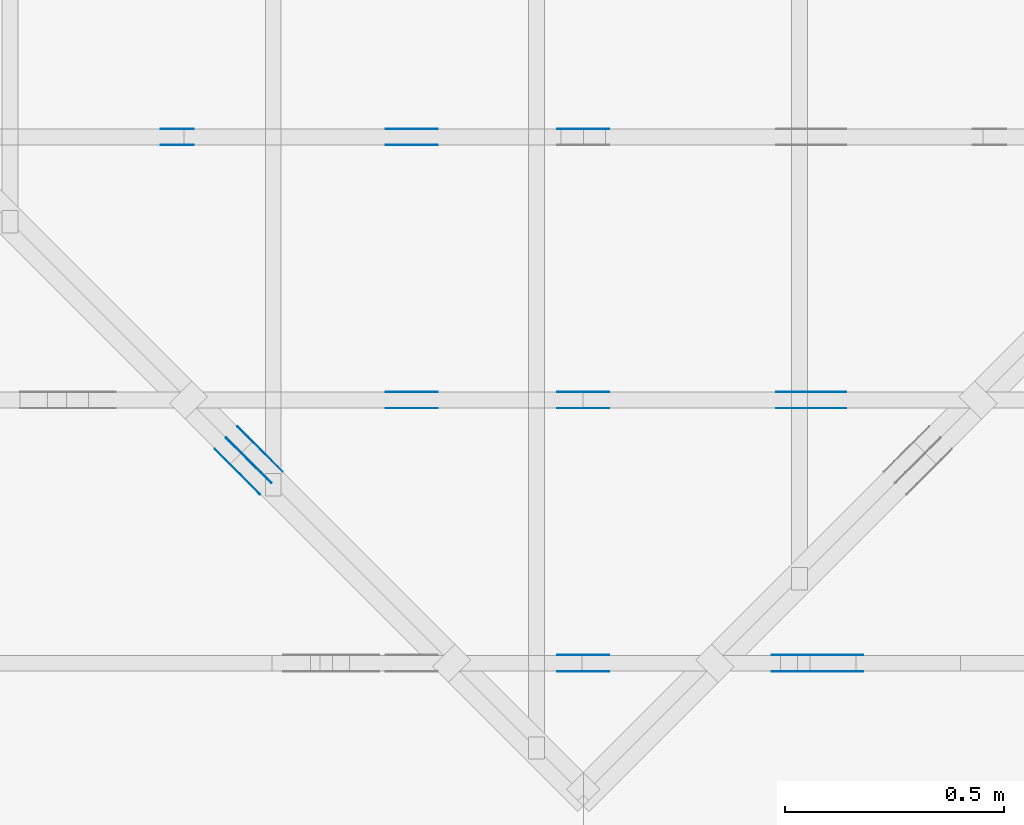
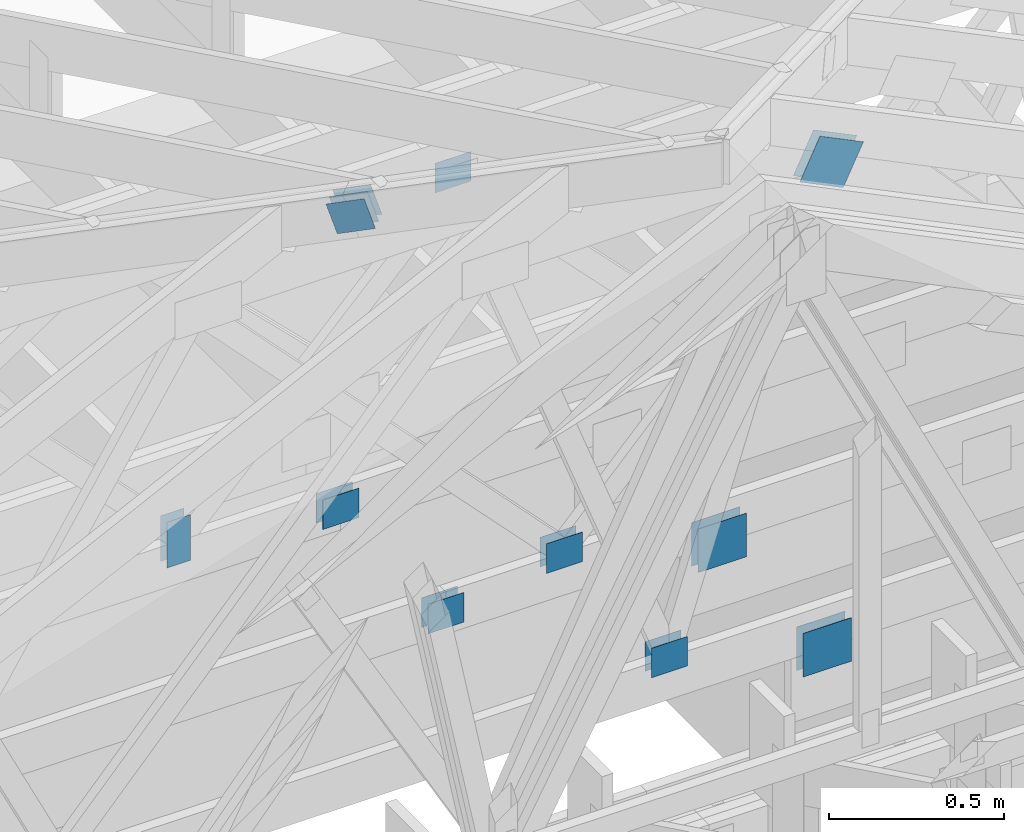
# One storey, part 106 of 159: 21 plates, 4 elements without a shape of their own.
"""IFC2X3 building model written with IfcOpenShell, lengths in millimetres."""

from ifc_helpers import new_model, si_unit, frame, origin, origin_with_axes, origin_2d, place, context, project, spatial, faceted_brep, element, aggregate, save


model = new_model("IFC2X3")

# Units and contexts
model_context = context("Model", 3, precision=1e-05, world=origin())
plan_context = context("Plan", 2, precision=1e-05, world=origin_2d())
ifc_project = project(units=[si_unit("LENGTHUNIT", "METRE", prefix="MILLI"), si_unit("AREAUNIT", "SQUARE_METRE"), si_unit("VOLUMEUNIT", "CUBIC_METRE"), si_unit("SOLIDANGLEUNIT", "STERADIAN"), si_unit("PLANEANGLEUNIT", "RADIAN"), si_unit("MASSUNIT", "GRAM"), si_unit("TIMEUNIT", "SECOND"), si_unit("THERMODYNAMICTEMPERATUREUNIT", "DEGREE_CELSIUS"), si_unit("LUMINOUSINTENSITYUNIT", "LUMEN")], contexts=[model_context, plan_context])

# Site, building, storey
site_placement = place(None, origin_with_axes())
site = spatial("IfcSite", under=ifc_project, at=site_placement, CompositionType="ELEMENT")
building_placement = place(site_placement, origin_with_axes())
building = spatial("IfcBuilding", under=site, at=building_placement, Name="Plan 1", CompositionType="ELEMENT")
storey_placement = place(building_placement, origin_with_axes())
storey = spatial("IfcBuildingStorey", under=building, at=storey_placement, Name="Etasje 1", CompositionType="ELEMENT", Elevation=0.0)

# Assembly, plates
assembly_1_placement = place(storey_placement, frame((19200.01266310149, 9617.999978540158, 1.1021457184401395e-15), z_axis=(1.2246063538223773e-16, 1.0, 6.123031769111886e-17), x_axis=(-1.0, 1.2246063538223773e-16, 0.0)))
assembly_1 = element("IfcElementAssembly", 1, at=assembly_1_placement, inside=storey, Name="V12 (104)", AssemblyPlace="FACTORY", PredefinedType="TRUSS")
plate_1_placement = place(assembly_1_placement, frame((4028.032541300384, 1806.4521257619804, 0.0), z_axis=(0.0, 0.0, 1.0), x_axis=(0.8987940462991673, 0.4383711467890768, 0.0)))
plate_1 = element("IfcPlate", 2, at=plate_1_placement, Name="GNT100S 152x159", context=model_context, shape_type="Brep", body=[
    faceted_brep([(158.99978113527595, 152.0001253083451, 1.0), (8.280817382910755e-05, 152.0001253083451, 1.0), (0.0, 0.0001610444935522537, 1.0), (159.00013719138315, 0.0001610444935522537, 1.0), (8.280817382910755e-05, 152.0001253083451, 1.01407415819553e-20), (158.99978113527595, 152.0001253083451, 1.947121422346263e-14), (159.00013719138315, 0.0, 1.9471257826319747e-14), (0.0, 0.0, 0.0), (159.00000636864752, 0.00011443024701051385, 5.160118521239647e-30), (159.00000636864752, 0.00011443024701057508, 1.0), (6.368647518684156e-06, 0.00011443024732222268, 1.0), (6.368647518684156e-06, 0.00011443024732216145, 0.0), (159.00000636864752, 152.00011443024732, 5.522026336547083e-29), (159.00000636864752, 152.00011443024732, 1.0), (159.00000636864752, 0.00011443024709478777, 1.0), (159.00000636864752, 0.00011443024709478777, 0.0), (6.368647518684156e-06, 152.00011443024687, 0.0), (6.368647518684156e-06, 152.00011443024687, 1.0), (159.0000063686466, 152.00011443024735, 1.0), (159.0000063686466, 152.00011443024735, 3.1554436208840472e-30), (6.368647518684171e-06, 0.00011443024732216145, -8.46355932592047e-37), (6.368647518745401e-06, 0.00011443024732216145, 1.0), (6.3686475373594175e-06, 152.00011443024687, 1.0), (6.368647537298187e-06, 152.00011443024687, -1.1397430066957006e-30)], [[[0, 1, 2, 3]], [[4, 5, 6, 7]], [[8, 9, 10, 11]], [[12, 13, 14, 15]], [[16, 17, 18, 19]], [[20, 21, 22, 23]]]),
])
plate_2_placement = place(assembly_1_placement, frame((4028.032541300384, 1806.4521257619804, -37.0), z_axis=(0.0, 0.0, 1.0), x_axis=(0.8987940462991673, 0.4383711467890768, 0.0)))
plate_2 = element("IfcPlate", 3, at=plate_2_placement, Name="GNT100S 152x159", context=model_context, shape_type="Brep", body=[
    faceted_brep([(158.99978113527595, 152.0001253083451, 1.0), (8.280817382910755e-05, 152.0001253083451, 1.0), (0.0, 0.0001610444935522537, 1.0), (159.00013719138315, 0.0001610444935522537, 1.0), (8.280817382910755e-05, 152.0001253083451, 1.01407415819553e-20), (158.99978113527595, 152.0001253083451, 1.947121422346263e-14), (159.00013719138315, 0.0, 1.9471257826319747e-14), (0.0, 0.0, 0.0), (159.00000636864752, 0.00011443024701051385, 5.160118521239647e-30), (159.00000636864752, 0.00011443024701057508, 1.0), (6.368647518684156e-06, 0.00011443024732222268, 1.0), (6.368647518684156e-06, 0.00011443024732216145, 0.0), (159.00000636864752, 152.00011443024732, 5.522026336547083e-29), (159.00000636864752, 152.00011443024732, 1.0), (159.00000636864752, 0.00011443024709478777, 1.0), (159.00000636864752, 0.00011443024709478777, 0.0), (6.368647518684156e-06, 152.00011443024687, 0.0), (6.368647518684156e-06, 152.00011443024687, 1.0), (159.0000063686466, 152.00011443024735, 1.0), (159.0000063686466, 152.00011443024735, 3.1554436208840472e-30), (6.368647518684171e-06, 0.00011443024732216145, -8.46355932592047e-37), (6.368647518745401e-06, 0.00011443024732216145, 1.0), (6.3686475373594175e-06, 152.00011443024687, 1.0), (6.368647537298187e-06, 152.00011443024687, -1.1397430066957006e-30)], [[[0, 1, 2, 3]], [[4, 5, 6, 7]], [[8, 9, 10, 11]], [[12, 13, 14, 15]], [[16, 17, 18, 19]], [[20, 21, 22, 23]]]),
])
plate_3_placement = place(assembly_1_placement, frame((4540.8310546875, 319.5, 0.0), z_axis=(0.0, 0.0, 1.0), x_axis=(1.0, 0.0, 0.0)))
plate_3 = element("IfcPlate", 4, at=plate_3_placement, Name="GNT100S 103x119", context=model_context, shape_type="Brep", body=[
    faceted_brep([(119.0, 103.0, 1.0), (0.0, 103.0, 1.0), (0.0, 0.0, 1.0), (119.0, 0.0, 1.0), (0.0, 103.0, 0.0), (119.0, 103.0, 1.457281561048629e-14), (119.0, 0.0, 1.457281561048629e-14), (0.0, 0.0, 0.0), (119.0000868137704, 9.444788812711026e-13, 1.338448170660265e-30), (119.0000868137704, 9.445401115887937e-13, 1.0), (8.681377039465588e-05, 9.663993350045231e-13, 1.0), (8.681377039465588e-05, 9.66338104686832e-13, 9.764340073010094e-37), (119.0000868137704, 103.00000000000097, 0.0), (119.0000868137704, 103.00000000000097, 1.0), (119.0000868137704, 9.663381206337363e-13, 1.0), (119.0000868137704, 9.663381206337363e-13, 0.0), (8.681377039465588e-05, 103.00000000000097, 0.0), (8.681377039465588e-05, 103.00000000000097, 1.0), (119.0000868137704, 103.00000000000095, 1.0), (119.0000868137704, 103.00000000000095, -7.888609052210118e-31), (8.681377039465588e-05, 9.663381206337363e-13, 0.0), (8.68137703947171e-05, 9.663381206337363e-13, 1.0), (8.681377040733055e-05, 103.00000000000097, 1.0), (8.681377040726932e-05, 103.00000000000097, -7.723249910891245e-31)], [[[0, 1, 2, 3]], [[4, 5, 6, 7]], [[8, 9, 10, 11]], [[12, 13, 14, 15]], [[16, 17, 18, 19]], [[20, 21, 22, 23]]]),
])
plate_4_placement = place(assembly_1_placement, frame((4540.8310546875, 319.5, -37.0), z_axis=(0.0, 0.0, 1.0), x_axis=(1.0, 0.0, 0.0)))
plate_4 = element("IfcPlate", 5, at=plate_4_placement, Name="GNT100S 103x119", context=model_context, shape_type="Brep", body=[
    faceted_brep([(119.0, 103.0, 1.0), (0.0, 103.0, 1.0), (0.0, 0.0, 1.0), (119.0, 0.0, 1.0), (0.0, 103.0, 0.0), (119.0, 103.0, 1.457281561048629e-14), (119.0, 0.0, 1.457281561048629e-14), (0.0, 0.0, 0.0), (119.0000868137704, 9.444788812711026e-13, 1.338448170660265e-30), (119.0000868137704, 9.445401115887937e-13, 1.0), (8.681377039465588e-05, 9.663993350045231e-13, 1.0), (8.681377039465588e-05, 9.66338104686832e-13, 9.764340073010094e-37), (119.0000868137704, 103.00000000000097, 0.0), (119.0000868137704, 103.00000000000097, 1.0), (119.0000868137704, 9.663381206337363e-13, 1.0), (119.0000868137704, 9.663381206337363e-13, 0.0), (8.681377039465588e-05, 103.00000000000097, 0.0), (8.681377039465588e-05, 103.00000000000097, 1.0), (119.0000868137704, 103.00000000000095, 1.0), (119.0000868137704, 103.00000000000095, -7.888609052210118e-31), (8.681377039465588e-05, 9.663381206337363e-13, 0.0), (8.68137703947171e-05, 9.663381206337363e-13, 1.0), (8.681377040733055e-05, 103.00000000000097, 1.0), (8.681377040726932e-05, 103.00000000000097, -7.723249910891245e-31)], [[[0, 1, 2, 3]], [[4, 5, 6, 7]], [[8, 9, 10, 11]], [[12, 13, 14, 15]], [[16, 17, 18, 19]], [[20, 21, 22, 23]]]),
])
plate_5_placement = place(assembly_1_placement, frame((4160.0, 299.00000000019014, 0.0), z_axis=(0.0, 0.0, 1.0), x_axis=(-1.0, 1.2246063538223773e-16, 0.0)))
plate_5 = element("IfcPlate", 6, at=plate_5_placement, Name="GNT100S 152x159", context=model_context, shape_type="Brep", body=[
    faceted_brep([(159.0, 152.00000000019014, 1.0), (0.0, 152.00000000019014, 1.0), (0.0, 1.901412360894028e-10, 1.0), (159.0, 1.901412360894028e-10, 1.0), (0.0, 152.00000000019014, 0.0), (159.0, 152.00000000019014, 1.9471241025775798e-14), (159.0, 1.901412360894028e-10, 1.9471241025775798e-14), (0.0, 1.901412360894028e-10, 0.0), (159.0, -2.92068615386637e-14, 1.788345410772899e-30), (159.0, -2.914563122097258e-14, 1.0), (1.1247455413666031e-32, 6.123031769111886e-17, 1.0), (0.0, 0.0, 0.0), (159.0, 152.00000000000003, 0.0), (159.0, 152.00000000000003, 1.0), (159.0, 0.0, 1.0), (159.0, 0.0, 0.0), (0.0, 152.0, 0.0), (0.0, 152.0, 1.0), (159.0, 152.00000000000003, 1.0), (159.0, 152.00000000000003, 0.0), (0.0, 0.0, 0.0), (6.123031769111886e-17, -7.498303609110687e-33, 1.0), (1.8675246895791253e-14, 152.0, 1.0), (1.8614016578100134e-14, 152.0, -1.1397421485848245e-30)], [[[0, 1, 2, 3]], [[4, 5, 6, 7]], [[8, 9, 10, 11]], [[12, 13, 14, 15]], [[16, 17, 18, 19]], [[20, 21, 22, 23]]]),
])
plate_6_placement = place(assembly_1_placement, frame((4160.0, 299.00000000019014, -37.0), z_axis=(0.0, 0.0, 1.0), x_axis=(-1.0, 1.2246063538223773e-16, 0.0)))
plate_6 = element("IfcPlate", 7, at=plate_6_placement, Name="GNT100S 152x159", context=model_context, shape_type="Brep", body=[
    faceted_brep([(159.0, 152.00000000019014, 1.0), (0.0, 152.00000000019014, 1.0), (0.0, 1.901412360894028e-10, 1.0), (159.0, 1.901412360894028e-10, 1.0), (0.0, 152.00000000019014, 0.0), (159.0, 152.00000000019014, 1.9471241025775798e-14), (159.0, 1.901412360894028e-10, 1.9471241025775798e-14), (0.0, 1.901412360894028e-10, 0.0), (159.0, -2.92068615386637e-14, 1.788345410772899e-30), (159.0, -2.914563122097258e-14, 1.0), (1.1247455413666031e-32, 6.123031769111886e-17, 1.0), (0.0, 0.0, 0.0), (159.0, 152.00000000000003, 0.0), (159.0, 152.00000000000003, 1.0), (159.0, 0.0, 1.0), (159.0, 0.0, 0.0), (0.0, 152.0, 0.0), (0.0, 152.0, 1.0), (159.0, 152.00000000000003, 1.0), (159.0, 152.00000000000003, 0.0), (0.0, 0.0, 0.0), (6.123031769111886e-17, -7.498303609110687e-33, 1.0), (1.8675246895791253e-14, 152.0, 1.0), (1.8614016578100134e-14, 152.0, -1.1397421485848245e-30)], [[[0, 1, 2, 3]], [[4, 5, 6, 7]], [[8, 9, 10, 11]], [[12, 13, 14, 15]], [[16, 17, 18, 19]], [[20, 21, 22, 23]]]),
])
aggregate(assembly_1, [plate_1, plate_2, plate_3, plate_4, plate_5, plate_6])

assembly_2_placement = place(storey_placement, frame((19200.01266310149, 10817.999978540158, 1.1021457184401395e-15), z_axis=(1.2246063538223773e-16, 1.0, 6.123031769111886e-17), x_axis=(-1.0, 1.2246063538223773e-16, 0.0)))
assembly_2 = element("IfcElementAssembly", 8, at=assembly_2_placement, inside=storey, Name="V10 (59)", AssemblyPlace="FACTORY", PredefinedType="TRUSS")
plate_7_placement = place(assembly_2_placement, frame((4659.5, 1362.0267333984375, 0.0), z_axis=(0.0, 0.0, 1.0), x_axis=(-1.0, 1.2246063538223773e-16, 0.0)))
plate_7 = element("IfcPlate", 9, at=plate_7_placement, Name="GNT100S 103x119", context=model_context, shape_type="Brep", body=[
    faceted_brep([(119.0, 103.0, 1.0), (0.0, 103.0, 1.0), (0.0, 0.0, 1.0), (119.0, 0.0, 1.0), (0.0, 103.0, 0.0), (119.0, 103.0, 1.457281561048629e-14), (119.0, 2.2737367544323206e-13, 1.457281561048629e-14), (0.0, 2.2737367544323206e-13, 0.0), (119.00000000106957, 1.2177599463382107e-05, 2.3173492506686754e-30), (119.00000000106957, 1.2177599463443337e-05, 1.0), (1.0695657692849636e-09, 1.2177599273916097e-05, 1.0), (1.0695657692849636e-09, 1.2177599273854867e-05, 0.0), (119.00000000106957, 103.0000121775995, 0.0), (119.00000000106957, 103.0000121775995, 1.0), (119.00000000106957, 1.2177599501228542e-05, 1.0), (119.00000000106957, 1.2177599501228542e-05, 0.0), (1.0695657692849636e-09, 103.00001217759927, 0.0), (1.0695657692849636e-09, 103.00001217759927, 1.0), (119.00000000106957, 103.0000121775995, 1.0), (119.00000000106957, 103.0000121775995, 0.0), (1.0695657692864548e-09, 1.2177599273854867e-05, -9.130744205508276e-38), (1.0695658305167725e-09, 1.2177599273854867e-05, 1.0), (1.0695784439622169e-09, 103.00001217759927, 1.0), (1.0695783827318992e-09, 103.00001217759927, -7.723253630458428e-31)], [[[0, 1, 2, 3]], [[4, 5, 6, 7]], [[8, 9, 10, 11]], [[12, 13, 14, 15]], [[16, 17, 18, 19]], [[20, 21, 22, 23]]]),
])
plate_8_placement = place(assembly_2_placement, frame((5563.72265625, 291.5, 0.0), z_axis=(0.0, 0.0, 1.0), x_axis=(6.123031769111886e-17, 1.0, 0.0)))
plate_8 = element("IfcPlate", 10, at=plate_8_placement, Name="GNT100S 76x159", context=model_context, shape_type="Brep", body=[
    faceted_brep([(159.0, 76.0, 1.0), (0.0, 76.0, 1.0), (0.0, 0.0, 1.0), (159.0, 0.0, 1.0), (0.0, 76.0, 0.0), (159.0, 76.0, 1.9471241025775798e-14), (159.0, 0.0, 1.9471241025775798e-14), (0.0, 0.0, 0.0), (159.00000000027137, 0.00014167937112496176, 1.7883448193523036e-30), (159.00000000027137, 0.000141679371125023, 1.0), (2.7137048164149746e-10, 0.00014167937115422985, 1.0), (2.7137048164149746e-10, 0.00014167937115416862, 0.0), (159.00000000027137, 76.00014167937115, 0.0), (159.00000000027137, 76.00014167937115, 1.0), (159.00000000027137, 0.00014167937115416862, 1.0), (159.00000000027137, 0.00014167937115416862, 0.0), (2.7137048164149746e-10, 76.00014167937115, 0.0), (2.7137048164149746e-10, 76.00014167937115, 1.0), (159.00000000027137, 76.00014167937114, 1.0), (159.00000000027137, 76.00014167937114, -7.888609052210118e-31), (2.7137048165884763e-10, 0.00014167937115416862, -1.0623558894148973e-36), (2.713705428891653e-10, 0.00014167937115416862, 1.0), (2.7137984989745437e-10, 76.00014167937115, 1.0), (2.713797886671367e-10, 76.00014167937115, -5.698721366483016e-31)], [[[0, 1, 2, 3]], [[4, 5, 6, 7]], [[8, 9, 10, 11]], [[12, 13, 14, 15]], [[16, 17, 18, 19]], [[20, 21, 22, 23]]]),
])
plate_9_placement = place(assembly_2_placement, frame((5563.72265625, 291.5, -37.0), z_axis=(0.0, 0.0, 1.0), x_axis=(6.123031769111886e-17, 1.0, 0.0)))
plate_9 = element("IfcPlate", 11, at=plate_9_placement, Name="GNT100S 76x159", context=model_context, shape_type="Brep", body=[
    faceted_brep([(159.0, 76.0, 1.0), (0.0, 76.0, 1.0), (0.0, 0.0, 1.0), (159.0, 0.0, 1.0), (0.0, 76.0, 0.0), (159.0, 76.0, 1.9471241025775798e-14), (159.0, 0.0, 1.9471241025775798e-14), (0.0, 0.0, 0.0), (159.00000000027137, 0.00014167937112496176, 1.7883448193523036e-30), (159.00000000027137, 0.000141679371125023, 1.0), (2.7137048164149746e-10, 0.00014167937115422985, 1.0), (2.7137048164149746e-10, 0.00014167937115416862, 0.0), (159.00000000027137, 76.00014167937115, 0.0), (159.00000000027137, 76.00014167937115, 1.0), (159.00000000027137, 0.00014167937115416862, 1.0), (159.00000000027137, 0.00014167937115416862, 0.0), (2.7137048164149746e-10, 76.00014167937115, 0.0), (2.7137048164149746e-10, 76.00014167937115, 1.0), (159.00000000027137, 76.00014167937114, 1.0), (159.00000000027137, 76.00014167937114, -7.888609052210118e-31), (2.7137048165884763e-10, 0.00014167937115416862, -1.0623558894148973e-36), (2.713705428891653e-10, 0.00014167937115416862, 1.0), (2.7137984989745437e-10, 76.00014167937115, 1.0), (2.713797886671367e-10, 76.00014167937115, -5.698721366483016e-31)], [[[0, 1, 2, 3]], [[4, 5, 6, 7]], [[8, 9, 10, 11]], [[12, 13, 14, 15]], [[16, 17, 18, 19]], [[20, 21, 22, 23]]]),
])
plate_10_placement = place(assembly_2_placement, frame((5050.6812956836075, 348.50000000000085, 0.0), z_axis=(0.0, 0.0, 1.0), x_axis=(-1.0, 1.2246063538223773e-16, 0.0)))
plate_10 = element("IfcPlate", 12, at=plate_10_placement, Name="GNT100S 103x119", context=model_context, shape_type="Brep", body=[
    faceted_brep([(119.00014333985746, 103.00000000000085, 1.0), (0.0001433398574590683, 103.00000000000085, 1.0), (0.0001433398574590683, 8.526512829121202e-13, 1.0), (119.00014333985746, 8.526512829121202e-13, 1.0), (0.0001433398574590683, 103.00000000000085, 1.755349002003689e-20), (119.00014333985746, 103.00000000000085, 1.457283316397631e-14), (119.00014333985746, 8.526512829121202e-13, 1.457283316397631e-14), (0.0001433398574590683, 8.526512829121202e-13, 1.755349002003689e-20), (119.0, -2.1859223415729434e-14, 1.3384471942262577e-30), (119.0, -2.1797993098038315e-14, 1.0), (1.1247455413666031e-32, 6.123031769111886e-17, 1.0), (0.0, 0.0, 0.0), (119.0, 103.00000000000003, 0.0), (119.0, 103.00000000000003, 1.0), (119.0, 0.0, 1.0), (119.0, 0.0, 0.0), (0.0, 103.0, 0.0), (0.0, 103.0, 1.0), (119.0, 103.00000000000001, 1.0), (119.0, 103.00000000000001, -7.888609052210118e-31), (0.0, 0.0, 0.0), (6.123031769111886e-17, -7.498303609110687e-33, 1.0), (1.2674675762061605e-14, 103.0, 1.0), (1.2613445444370486e-14, 103.0, -7.723252717384008e-31)], [[[0, 1, 2, 3]], [[4, 5, 6, 7]], [[8, 9, 10, 11]], [[12, 13, 14, 15]], [[16, 17, 18, 19]], [[20, 21, 22, 23]]]),
])
plate_11_placement = place(assembly_2_placement, frame((5050.6812956836075, 348.50000000000085, -37.0), z_axis=(0.0, 0.0, 1.0), x_axis=(-1.0, 1.2246063538223773e-16, 0.0)))
plate_11 = element("IfcPlate", 13, at=plate_11_placement, Name="GNT100S 103x119", context=model_context, shape_type="Brep", body=[
    faceted_brep([(119.00014333985746, 103.00000000000085, 1.0), (0.0001433398574590683, 103.00000000000085, 1.0), (0.0001433398574590683, 8.526512829121202e-13, 1.0), (119.00014333985746, 8.526512829121202e-13, 1.0), (0.0001433398574590683, 103.00000000000085, 1.755349002003689e-20), (119.00014333985746, 103.00000000000085, 1.457283316397631e-14), (119.00014333985746, 8.526512829121202e-13, 1.457283316397631e-14), (0.0001433398574590683, 8.526512829121202e-13, 1.755349002003689e-20), (119.0, -2.1859223415729434e-14, 1.3384471942262577e-30), (119.0, -2.1797993098038315e-14, 1.0), (1.1247455413666031e-32, 6.123031769111886e-17, 1.0), (0.0, 0.0, 0.0), (119.0, 103.00000000000003, 0.0), (119.0, 103.00000000000003, 1.0), (119.0, 0.0, 1.0), (119.0, 0.0, 0.0), (0.0, 103.0, 0.0), (0.0, 103.0, 1.0), (119.0, 103.00000000000001, 1.0), (119.0, 103.00000000000001, -7.888609052210118e-31), (0.0, 0.0, 0.0), (6.123031769111886e-17, -7.498303609110687e-33, 1.0), (1.2674675762061605e-14, 103.0, 1.0), (1.2613445444370486e-14, 103.0, -7.723252717384008e-31)], [[[0, 1, 2, 3]], [[4, 5, 6, 7]], [[8, 9, 10, 11]], [[12, 13, 14, 15]], [[16, 17, 18, 19]], [[20, 21, 22, 23]]]),
])
aggregate(assembly_2, [plate_7, plate_8, plate_9, plate_10, plate_11])

assembly_3_placement = place(storey_placement, frame((19200.01266310149, 10217.999978540158, 1.1021457184401395e-15), z_axis=(1.2246063538223773e-16, 1.0, 6.123031769111886e-17), x_axis=(-1.0, 1.2246063538223773e-16, 0.0)))
assembly_3 = element("IfcElementAssembly", 14, at=assembly_3_placement, inside=storey, Name="V11 (60)", AssemblyPlace="FACTORY", PredefinedType="TRUSS")
plate_12_placement = place(assembly_3_placement, frame((5050.681295681745, 348.50000000000114, 0.0), z_axis=(0.0, 0.0, 1.0), x_axis=(-1.0, 1.2246063538223773e-16, 0.0)))
plate_12 = element("IfcPlate", 15, at=plate_12_placement, Name="GNT100S 103x119", context=model_context, shape_type="Brep", body=[
    faceted_brep([(119.00014333799481, 103.00000000000114, 1.0), (0.00014333799481391907, 103.00000000000114, 1.0), (0.00014333799481391907, 1.1368683772161603e-12, 1.0), (119.00014333799481, 1.1368683772161603e-12, 1.0), (0.00014333799481391907, 103.00000000000114, 1.7553261919328425e-20), (119.00014333799481, 103.00000000000114, 1.457283316374821e-14), (119.00014333799481, 1.1368683772161603e-12, 1.457283316374821e-14), (0.00014333799481391907, 1.1368683772161603e-12, 1.7553261919328425e-20), (119.0, -2.1859223415729434e-14, 1.3384471942262577e-30), (119.0, -2.1797993098038315e-14, 1.0), (1.1247455413666031e-32, 6.123031769111886e-17, 1.0), (0.0, 0.0, 0.0), (119.0, 103.00000000000003, 0.0), (119.0, 103.00000000000003, 1.0), (119.0, 0.0, 1.0), (119.0, 0.0, 0.0), (0.0, 103.0, 0.0), (0.0, 103.0, 1.0), (119.0, 103.00000000000001, 1.0), (119.0, 103.00000000000001, -7.888609052210118e-31), (0.0, 0.0, 0.0), (6.123031769111886e-17, -7.498303609110687e-33, 1.0), (1.2674675762061605e-14, 103.0, 1.0), (1.2613445444370486e-14, 103.0, -7.723252717384008e-31)], [[[0, 1, 2, 3]], [[4, 5, 6, 7]], [[8, 9, 10, 11]], [[12, 13, 14, 15]], [[16, 17, 18, 19]], [[20, 21, 22, 23]]]),
])
plate_13_placement = place(assembly_3_placement, frame((5050.681295681745, 348.50000000000114, -37.0), z_axis=(0.0, 0.0, 1.0), x_axis=(-1.0, 1.2246063538223773e-16, 0.0)))
plate_13 = element("IfcPlate", 16, at=plate_13_placement, Name="GNT100S 103x119", context=model_context, shape_type="Brep", body=[
    faceted_brep([(119.00014333799481, 103.00000000000114, 1.0), (0.00014333799481391907, 103.00000000000114, 1.0), (0.00014333799481391907, 1.1368683772161603e-12, 1.0), (119.00014333799481, 1.1368683772161603e-12, 1.0), (0.00014333799481391907, 103.00000000000114, 1.7553261919328425e-20), (119.00014333799481, 103.00000000000114, 1.457283316374821e-14), (119.00014333799481, 1.1368683772161603e-12, 1.457283316374821e-14), (0.00014333799481391907, 1.1368683772161603e-12, 1.7553261919328425e-20), (119.0, -2.1859223415729434e-14, 1.3384471942262577e-30), (119.0, -2.1797993098038315e-14, 1.0), (1.1247455413666031e-32, 6.123031769111886e-17, 1.0), (0.0, 0.0, 0.0), (119.0, 103.00000000000003, 0.0), (119.0, 103.00000000000003, 1.0), (119.0, 0.0, 1.0), (119.0, 0.0, 0.0), (0.0, 103.0, 0.0), (0.0, 103.0, 1.0), (119.0, 103.00000000000001, 1.0), (119.0, 103.00000000000001, -7.888609052210118e-31), (0.0, 0.0, 0.0), (6.123031769111886e-17, -7.498303609110687e-33, 1.0), (1.2674675762061605e-14, 103.0, 1.0), (1.2613445444370486e-14, 103.0, -7.723252717384008e-31)], [[[0, 1, 2, 3]], [[4, 5, 6, 7]], [[8, 9, 10, 11]], [[12, 13, 14, 15]], [[16, 17, 18, 19]], [[20, 21, 22, 23]]]),
])
plate_14_placement = place(assembly_3_placement, frame((4540.65087890625, 319.5, 0.0), z_axis=(0.0, 0.0, 1.0), x_axis=(1.0, 0.0, 0.0)))
plate_14 = element("IfcPlate", 17, at=plate_14_placement, Name="GNT100S 103x119", context=model_context, shape_type="Brep", body=[
    faceted_brep([(119.0, 103.0, 1.0), (0.0, 103.0, 1.0), (0.0, 0.0, 1.0), (119.0, 0.0, 1.0), (0.0, 103.0, 0.0), (119.0, 103.0, 1.457281561048629e-14), (119.0, 0.0, 1.457281561048629e-14), (0.0, 0.0, 0.0), (119.0000343062784, 1.001322309777062e-12, 1.3384475800845966e-30), (119.0000343062784, 1.001383540094753e-12, 1.0), (3.430627839406952e-05, 1.0232427635104825e-12, 1.0), (3.430627839406952e-05, 1.0231815331927914e-12, 3.8585833896559525e-37), (119.0000343062784, 103.00000000000102, 0.0), (119.0000343062784, 103.00000000000102, 1.0), (119.0000343062784, 1.0231815394945443e-12, 1.0), (119.0000343062784, 1.0231815394945443e-12, 0.0), (3.430627839406952e-05, 103.00000000000102, 0.0), (3.430627839406952e-05, 103.00000000000102, 1.0), (119.0000343062784, 103.00000000000101, 1.0), (119.0000343062784, 103.00000000000101, -7.888609052210118e-31), (3.430627839406952e-05, 1.0231815394945443e-12, 0.0), (3.430627839413075e-05, 1.0231815394945443e-12, 1.0), (3.43062784067442e-05, 103.00000000000102, 1.0), (3.430627840668297e-05, 103.00000000000102, -7.723253672473168e-31)], [[[0, 1, 2, 3]], [[4, 5, 6, 7]], [[8, 9, 10, 11]], [[12, 13, 14, 15]], [[16, 17, 18, 19]], [[20, 21, 22, 23]]]),
])
plate_15_placement = place(assembly_3_placement, frame((4540.65087890625, 319.5, -37.0), z_axis=(0.0, 0.0, 1.0), x_axis=(1.0, 0.0, 0.0)))
plate_15 = element("IfcPlate", 18, at=plate_15_placement, Name="GNT100S 103x119", context=model_context, shape_type="Brep", body=[
    faceted_brep([(119.0, 103.0, 1.0), (0.0, 103.0, 1.0), (0.0, 0.0, 1.0), (119.0, 0.0, 1.0), (0.0, 103.0, 0.0), (119.0, 103.0, 1.457281561048629e-14), (119.0, 0.0, 1.457281561048629e-14), (0.0, 0.0, 0.0), (119.0000343062784, 1.001322309777062e-12, 1.3384475800845966e-30), (119.0000343062784, 1.001383540094753e-12, 1.0), (3.430627839406952e-05, 1.0232427635104825e-12, 1.0), (3.430627839406952e-05, 1.0231815331927914e-12, 3.8585833896559525e-37), (119.0000343062784, 103.00000000000102, 0.0), (119.0000343062784, 103.00000000000102, 1.0), (119.0000343062784, 1.0231815394945443e-12, 1.0), (119.0000343062784, 1.0231815394945443e-12, 0.0), (3.430627839406952e-05, 103.00000000000102, 0.0), (3.430627839406952e-05, 103.00000000000102, 1.0), (119.0000343062784, 103.00000000000101, 1.0), (119.0000343062784, 103.00000000000101, -7.888609052210118e-31), (3.430627839406952e-05, 1.0231815394945443e-12, 0.0), (3.430627839413075e-05, 1.0231815394945443e-12, 1.0), (3.43062784067442e-05, 103.00000000000102, 1.0), (3.430627840668297e-05, 103.00000000000102, -7.723253672473168e-31)], [[[0, 1, 2, 3]], [[4, 5, 6, 7]], [[8, 9, 10, 11]], [[12, 13, 14, 15]], [[16, 17, 18, 19]], [[20, 21, 22, 23]]]),
])
plate_16_placement = place(assembly_3_placement, frame((4160.0, 299.0, 0.0), z_axis=(0.0, 0.0, 1.0), x_axis=(-1.0, 1.2246063538223773e-16, 0.0)))
plate_16 = element("IfcPlate", 19, at=plate_16_placement, Name="GNT100S 152x159", context=model_context, shape_type="Brep", body=[
    faceted_brep([(159.0, 152.0, 1.0), (0.0, 152.0, 1.0), (0.0, 0.0, 1.0), (159.0, 0.0, 1.0), (0.0, 152.0, 0.0), (159.0, 152.0, 1.9471241025775798e-14), (159.0, 0.0, 1.9471241025775798e-14), (0.0, 0.0, 0.0), (159.0, -2.92068615386637e-14, 1.788345410772899e-30), (159.0, -2.914563122097258e-14, 1.0), (1.1247455413666031e-32, 6.123031769111886e-17, 1.0), (0.0, 0.0, 0.0), (159.0, 152.00000000000003, 0.0), (159.0, 152.00000000000003, 1.0), (159.0, 0.0, 1.0), (159.0, 0.0, 0.0), (0.0, 152.0, 0.0), (0.0, 152.0, 1.0), (159.0, 152.00000000000003, 1.0), (159.0, 152.00000000000003, 0.0), (0.0, 0.0, 0.0), (6.123031769111886e-17, -7.498303609110687e-33, 1.0), (1.8675246895791253e-14, 152.0, 1.0), (1.8614016578100134e-14, 152.0, -1.1397421485848245e-30)], [[[0, 1, 2, 3]], [[4, 5, 6, 7]], [[8, 9, 10, 11]], [[12, 13, 14, 15]], [[16, 17, 18, 19]], [[20, 21, 22, 23]]]),
])
plate_17_placement = place(assembly_3_placement, frame((4160.0, 299.0, -37.0), z_axis=(0.0, 0.0, 1.0), x_axis=(-1.0, 1.2246063538223773e-16, 0.0)))
plate_17 = element("IfcPlate", 20, at=plate_17_placement, Name="GNT100S 152x159", context=model_context, shape_type="Brep", body=[
    faceted_brep([(159.0, 152.0, 1.0), (0.0, 152.0, 1.0), (0.0, 0.0, 1.0), (159.0, 0.0, 1.0), (0.0, 152.0, 0.0), (159.0, 152.0, 1.9471241025775798e-14), (159.0, 0.0, 1.9471241025775798e-14), (0.0, 0.0, 0.0), (159.0, -2.92068615386637e-14, 1.788345410772899e-30), (159.0, -2.914563122097258e-14, 1.0), (1.1247455413666031e-32, 6.123031769111886e-17, 1.0), (0.0, 0.0, 0.0), (159.0, 152.00000000000003, 0.0), (159.0, 152.00000000000003, 1.0), (159.0, 0.0, 1.0), (159.0, 0.0, 0.0), (0.0, 152.0, 0.0), (0.0, 152.0, 1.0), (159.0, 152.00000000000003, 1.0), (159.0, 152.00000000000003, 0.0), (0.0, 0.0, 0.0), (6.123031769111886e-17, -7.498303609110687e-33, 1.0), (1.8675246895791253e-14, 152.0, 1.0), (1.8614016578100134e-14, 152.0, -1.1397421485848245e-30)], [[[0, 1, 2, 3]], [[4, 5, 6, 7]], [[8, 9, 10, 11]], [[12, 13, 14, 15]], [[16, 17, 18, 19]], [[20, 21, 22, 23]]]),
])
aggregate(assembly_3, [plate_12, plate_13, plate_14, plate_15, plate_16, plate_17])

assembly_4_placement = place(storey_placement, frame((9974.55681897877, 13874.544134417441, 2.204291436880279e-15), z_axis=(-0.7071067811865477, -0.7071067811865474, 6.123031769111886e-17), x_axis=(0.7071067811865474, -0.7071067811865477, 0.0)))
assembly_4 = element("IfcElementAssembly", 21, at=assembly_4_placement, inside=storey, Name="GR2 (61)", AssemblyPlace="FACTORY", PredefinedType="TRUSS")
plate_18_placement = place(assembly_4_placement, frame((5387.349966256832, 1839.022171479972, 0.0), z_axis=(0.0, 0.0, 1.0), x_axis=(0.9453579955214151, 0.3260341397825261, 0.0)))
plate_18 = element("IfcPlate", 22, at=plate_18_placement, Name="GNT100S 103x119", context=model_context, shape_type="Brep", body=[
    faceted_brep([(119.00006868290347, 102.99996388448994, 1.0), (9.843189491220983e-05, 102.99996388448994, 1.0), (0.00013899434725317406, 0.0, 1.0), (119.00010924535582, 0.0, 1.0), (9.843189491220983e-05, 102.99996388448994, 1.2054032392826868e-20), (119.00006868290347, 102.99996388448994, 1.457282402143829e-14), (119.00010924535582, 4.524020687313168e-05, 1.4572828988741977e-14), (0.00013899434725317406, 4.524020687313168e-05, 1.7021336079163084e-20), (119.0, 4.3152705037198216e-05, 2.3173492506686754e-30), (119.0, 4.3152705037259446e-05, 1.0), (-9.752427755890866e-32, 4.3152704847732205e-05, 1.0), (0.0, 4.3152704847670975e-05, 0.0), (119.0, 103.00004315270508, 0.0), (119.0, 103.00004315270508, 1.0), (119.0, 4.315270507504465e-05, 1.0), (119.0, 4.315270507504465e-05, 0.0), (0.0, 103.00004315270508, 0.0), (-3.7491518045553436e-33, 103.00004315270508, 1.0), (119.0, 103.00004315270506, 1.0), (119.0, 103.00004315270506, -7.888609052210118e-31), (5.284507654107958e-21, 4.3152704847670975e-05, -3.235720825021795e-37), (6.123560219877297e-17, 4.3152704847670975e-05, 1.0), (1.2674681046569286e-14, 103.00004315270508, 1.0), (1.2613450728878167e-14, 103.00004315270508, -7.72325595310485e-31)], [[[0, 1, 2, 3]], [[4, 5, 6, 7]], [[8, 9, 10, 11]], [[12, 13, 14, 15]], [[16, 17, 18, 19]], [[20, 21, 22, 23]]]),
])
plate_19_placement = place(assembly_4_placement, frame((5387.349966256832, 1839.022171479972, -36.99999999999999), z_axis=(0.0, 0.0, 1.0), x_axis=(0.9453579955214151, 0.3260341397825261, 0.0)))
plate_19 = element("IfcPlate", 23, at=plate_19_placement, Name="GNT100S 103x119", context=model_context, shape_type="Brep", body=[
    faceted_brep([(119.00006868290347, 102.99996388448994, 1.0), (9.843189491220983e-05, 102.99996388448994, 1.0), (0.00013899434725317406, 0.0, 1.0), (119.00010924535582, 0.0, 1.0), (9.843189491220983e-05, 102.99996388448994, 1.2054032392826868e-20), (119.00006868290347, 102.99996388448994, 1.457282402143829e-14), (119.00010924535582, 4.524020687313168e-05, 1.4572828988741977e-14), (0.00013899434725317406, 4.524020687313168e-05, 1.7021336079163084e-20), (119.0, 4.3152705037198216e-05, 2.3173492506686754e-30), (119.0, 4.3152705037259446e-05, 1.0), (-9.752427755890866e-32, 4.3152704847732205e-05, 1.0), (0.0, 4.3152704847670975e-05, 0.0), (119.0, 103.00004315270508, 0.0), (119.0, 103.00004315270508, 1.0), (119.0, 4.315270507504465e-05, 1.0), (119.0, 4.315270507504465e-05, 0.0), (0.0, 103.00004315270508, 0.0), (-3.7491518045553436e-33, 103.00004315270508, 1.0), (119.0, 103.00004315270506, 1.0), (119.0, 103.00004315270506, -7.888609052210118e-31), (5.284507654107958e-21, 4.3152704847670975e-05, -3.235720825021795e-37), (6.123560219877297e-17, 4.3152704847670975e-05, 1.0), (1.2674681046569286e-14, 103.00004315270508, 1.0), (1.2613450728878167e-14, 103.00004315270508, -7.72325595310485e-31)], [[[0, 1, 2, 3]], [[4, 5, 6, 7]], [[8, 9, 10, 11]], [[12, 13, 14, 15]], [[16, 17, 18, 19]], [[20, 21, 22, 23]]]),
])
plate_20_placement = place(assembly_4_placement, frame((5387.349966256832, 1839.022171479972, -36.0), z_axis=(0.0, 0.0, 1.0), x_axis=(0.9453579955214151, 0.3260341397825261, 0.0)))
plate_20 = element("IfcPlate", 24, at=plate_20_placement, Name="GNT100S 103x119", context=model_context, shape_type="Brep", body=[
    faceted_brep([(119.00006868290347, 102.99996388448994, 1.0), (9.843189491220983e-05, 102.99996388448994, 1.0), (0.00013899434725317406, 0.0, 1.0), (119.00010924535582, 0.0, 1.0), (9.843189491220983e-05, 102.99996388448994, 1.2054032392826868e-20), (119.00006868290347, 102.99996388448994, 1.457282402143829e-14), (119.00010924535582, 4.524020687313168e-05, 1.4572828988741977e-14), (0.00013899434725317406, 4.524020687313168e-05, 1.7021336079163084e-20), (119.0, 4.3152705037198216e-05, 2.3173492506686754e-30), (119.0, 4.3152705037259446e-05, 1.0), (-9.752427755890866e-32, 4.3152704847732205e-05, 1.0), (0.0, 4.3152704847670975e-05, 0.0), (119.0, 103.00004315270508, 0.0), (119.0, 103.00004315270508, 1.0), (119.0, 4.315270507504465e-05, 1.0), (119.0, 4.315270507504465e-05, 0.0), (0.0, 103.00004315270508, 0.0), (-3.7491518045553436e-33, 103.00004315270508, 1.0), (119.0, 103.00004315270506, 1.0), (119.0, 103.00004315270506, -7.888609052210118e-31), (5.284507654107958e-21, 4.3152704847670975e-05, -3.235720825021795e-37), (6.123560219877297e-17, 4.3152704847670975e-05, 1.0), (1.2674681046569286e-14, 103.00004315270508, 1.0), (1.2613450728878167e-14, 103.00004315270508, -7.72325595310485e-31)], [[[0, 1, 2, 3]], [[4, 5, 6, 7]], [[8, 9, 10, 11]], [[12, 13, 14, 15]], [[16, 17, 18, 19]], [[20, 21, 22, 23]]]),
])
plate_21_placement = place(assembly_4_placement, frame((5387.349966256832, 1839.022171479972, -72.99999999999999), z_axis=(0.0, 0.0, 1.0), x_axis=(0.9453579955214151, 0.3260341397825261, 0.0)))
plate_21 = element("IfcPlate", 25, at=plate_21_placement, Name="GNT100S 103x119", context=model_context, shape_type="Brep", body=[
    faceted_brep([(119.00006868290347, 102.99996388448994, 1.0), (9.843189491220983e-05, 102.99996388448994, 1.0), (0.00013899434725317406, 0.0, 1.0), (119.00010924535582, 0.0, 1.0), (9.843189491220983e-05, 102.99996388448994, 1.2054032392826868e-20), (119.00006868290347, 102.99996388448994, 1.457282402143829e-14), (119.00010924535582, 4.524020687313168e-05, 1.4572828988741977e-14), (0.00013899434725317406, 4.524020687313168e-05, 1.7021336079163084e-20), (119.0, 4.3152705037198216e-05, 2.3173492506686754e-30), (119.0, 4.3152705037259446e-05, 1.0), (-9.752427755890866e-32, 4.3152704847732205e-05, 1.0), (0.0, 4.3152704847670975e-05, 0.0), (119.0, 103.00004315270508, 0.0), (119.0, 103.00004315270508, 1.0), (119.0, 4.315270507504465e-05, 1.0), (119.0, 4.315270507504465e-05, 0.0), (0.0, 103.00004315270508, 0.0), (-3.7491518045553436e-33, 103.00004315270508, 1.0), (119.0, 103.00004315270506, 1.0), (119.0, 103.00004315270506, -7.888609052210118e-31), (5.284507654107958e-21, 4.3152704847670975e-05, -3.235720825021795e-37), (6.123560219877297e-17, 4.3152704847670975e-05, 1.0), (1.2674681046569286e-14, 103.00004315270508, 1.0), (1.2613450728878167e-14, 103.00004315270508, -7.72325595310485e-31)], [[[0, 1, 2, 3]], [[4, 5, 6, 7]], [[8, 9, 10, 11]], [[12, 13, 14, 15]], [[16, 17, 18, 19]], [[20, 21, 22, 23]]]),
])
aggregate(assembly_4, [plate_18, plate_19, plate_20, plate_21])

save(model, "model.ifc")
